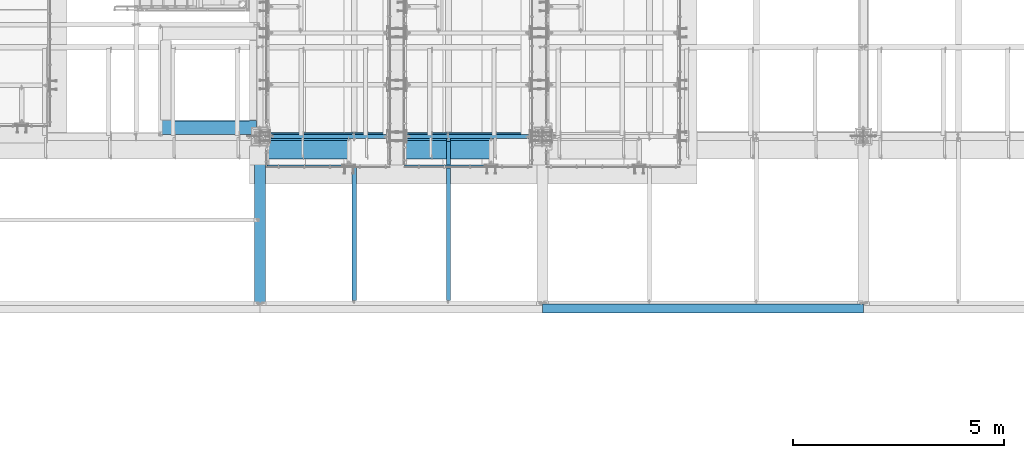
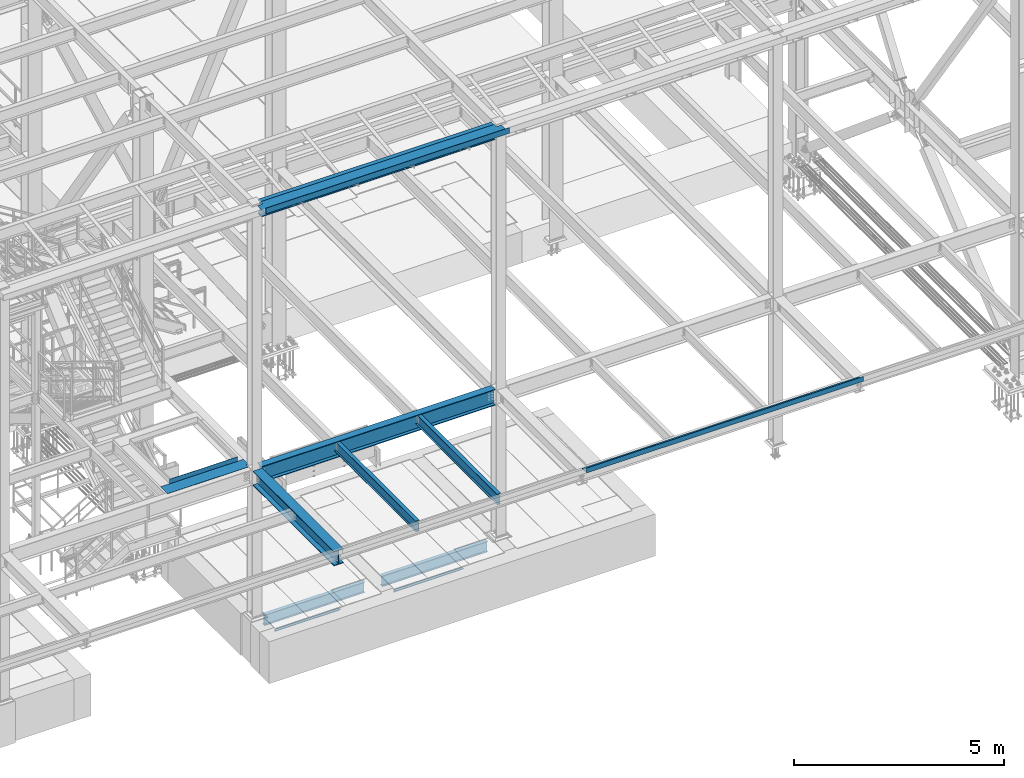
# One storey, part 1751 of 3843: 12 beams, 11 elements without a shape of their own.
"""IFC2X3 building model written with IfcOpenShell, lengths in millimetres."""

from ifc_helpers import new_model, si_unit, frame, origin_with_axes, place, context, subcontext, project, spatial, faceted_brep, material, type_object, element, aggregate, save


model = new_model("IFC2X3")

# Units and contexts
model_context = context("Model", 3, precision=1e-05, world=origin_with_axes())
body_context = subcontext(model_context, "Body", "Model", "MODEL_VIEW")
ifc_project = project(units=[si_unit("LENGTHUNIT", "METRE", prefix="MILLI"), si_unit("AREAUNIT", "SQUARE_METRE"), si_unit("VOLUMEUNIT", "CUBIC_METRE"), si_unit("MASSUNIT", "GRAM", prefix="KILO"), si_unit("TIMEUNIT", "SECOND"), si_unit("PLANEANGLEUNIT", "RADIAN"), si_unit("SOLIDANGLEUNIT", "STERADIAN"), si_unit("THERMODYNAMICTEMPERATUREUNIT", "DEGREE_CELSIUS"), si_unit("LUMINOUSINTENSITYUNIT", "LUMEN")], contexts=[model_context])

# Site, building, storey
site_placement = place(None, origin_with_axes())
site = spatial("IfcSite", under=ifc_project, at=site_placement, CompositionType="ELEMENT")
building_placement = place(site_placement, origin_with_axes())
building = spatial("IfcBuilding", under=site, at=building_placement, Name="Undefined", CompositionType="ELEMENT")
storey_placement = place(building_placement, origin_with_axes())
storey = spatial("IfcBuildingStorey", under=building, at=storey_placement, Name="Undefined", CompositionType="ELEMENT", Elevation=0.0)

# Assembly, beam
assembly_1_placement = place(storey_placement, origin_with_axes())
assembly_1 = element("IfcElementAssembly", 1, at=assembly_1_placement, inside=storey, Name="ANGLE", AssemblyPlace="NOTDEFINED", PredefinedType="RIGID_FRAME")
ifc_material_1 = material(Name="STEEL/A36")
beam_type_1 = type_object("IfcBeamType", Name="L3X3X1/4", PredefinedType="NOTDEFINED")
beam_1_placement = place(assembly_1_placement, frame((57873.8999936549, 14290.6743626722, 30391.1000030518), z_axis=(0.0, 0.0, -1.0), x_axis=(-1.0, 0.0, 0.0)))
beam_1 = element("IfcBeam", 2, at=beam_1_placement, type_object=beam_type_1, material=ifc_material_1, Name="ANGLE", ObjectType="L3X3X1/4", context=body_context, shape_type="Brep", body=[
    faceted_brep([(0.0, 38.0999999999985, -38.0999999999985), (0.0, 38.0999999999985, 38.0999999999985), (1784.34998101931, 38.0999999996202, 38.0999999999985), (1784.34998101931, 38.0999999996202, -38.0999999999985), (0.0, 31.75, 38.0999999999985), (1784.34998101932, 31.7499999996198, 38.0999999999985), (0.0, 31.75, -31.75), (1784.34998101932, 31.7499999996198, -31.75), (0.0, -38.0999999999985, -31.75), (1784.34998101943, -38.1000000003805, -31.75), (0.0, -38.0999999999985, -38.0999999999985), (1784.34998101943, -38.1000000003805, -38.0999999999985)], [[[0, 1, 2, 3]], [[1, 4, 5, 2]], [[4, 6, 7, 5]], [[6, 8, 9, 7]], [[8, 10, 11, 9]], [[10, 0, 3, 11]], [[5, 7, 9, 11, 3, 2]], [[10, 8, 6, 4, 1, 0]]]),
])
aggregate(assembly_1, [beam_1])

assembly_2_placement = place(storey_placement, origin_with_axes())
assembly_2 = element("IfcElementAssembly", 3, at=assembly_2_placement, inside=storey, Name="ANGLE", AssemblyPlace="NOTDEFINED", PredefinedType="RIGID_FRAME")
beam_2_placement = place(assembly_2_placement, frame((61255.2750461689, 14290.6746402423, 30391.1000030518), z_axis=(0.0, 0.0, -1.0), x_axis=(-1.0, 0.0, 0.0)))
beam_2 = element("IfcBeam", 4, at=beam_2_placement, type_object=beam_type_1, material=ifc_material_1, Name="ANGLE", ObjectType="L3X3X1/4", context=body_context, shape_type="Brep", body=[
    faceted_brep([(0.0, 38.0999999999985, -38.0999999999985), (0.0, 38.0999999999985, 38.0999999999985), (1895.47503339566, 38.0999999996784, 38.0999999999985), (1895.47503339566, 38.0999999996784, -38.0999999999985), (0.0, 31.75, 38.0999999999985), (1895.47503339566, 31.749999999678, 38.0999999999985), (0.0, 31.75, -31.75), (1895.47503339566, 31.749999999678, -31.75), (0.0, -38.0999999999985, -31.75), (1895.47503339565, -38.1000000003205, -31.75), (0.0, -38.0999999999985, -38.0999999999985), (1895.47503339565, -38.1000000003205, -38.0999999999985)], [[[0, 1, 2, 3]], [[1, 4, 5, 2]], [[4, 6, 7, 5]], [[6, 8, 9, 7]], [[8, 10, 11, 9]], [[10, 0, 3, 11]], [[5, 7, 9, 11, 3, 2]], [[10, 8, 6, 4, 1, 0]]]),
])
aggregate(assembly_2, [beam_2])

assembly_3_placement = place(storey_placement, origin_with_axes())
assembly_3 = element("IfcElementAssembly", 5, at=assembly_3_placement, inside=storey, Name="BEAM", AssemblyPlace="NOTDEFINED", PredefinedType="RIGID_FRAME")
ifc_material_2 = material(Name="STEEL/A992")
beam_type_2 = type_object("IfcBeamType", Name="W12X19", PredefinedType="NOTDEFINED")
beam_3_placement = place(assembly_3_placement, frame((58166.0, 11036.3, 34656.7125), z_axis=(0.0, 0.0, 1.0), x_axis=(0.0, 1.0, 0.0)))
beam_3 = element("IfcBeam", 6, at=beam_3_placement, type_object=beam_type_2, material=ifc_material_2, Name="BEAM", ObjectType="W12X19", context=body_context, shape_type="Brep", body=[
    faceted_brep([(15.8750000000146, -3.17500000000291, -128.587499998961), (15.8750000000146, 3.17500000000291, -128.587499998961), (53.9750001907523, 3.17500000000291, -128.587499998961), (53.9750001907523, -3.17500000000291, -128.587499998961), (58.8350797087915, 3.17500000000291, -129.554229921552), (58.8350797087915, -3.17500000000291, -129.554229921552), (62.9552561769524, 3.17500000000291, -132.307243822026), (62.9552561769524, -3.17500000000291, -132.307243822026), (65.7082700774336, 3.17500000000291, -136.42742029018), (65.7082700774336, -3.17500000000291, -136.42742029018), (66.6750000000175, -3.17500000000291, -141.287499808226), (66.6750000000175, 3.17500000000291, -141.287499808226), (66.6750000000175, 3.17500000000291, -144.462500000001), (66.6750000000175, 50.8000000000029, -144.462500000001), (66.6750000000175, 50.8000000000029, -153.987500000003), (66.6750000000175, -50.8000000000029, -153.987500000003), (66.6750000000175, -50.8000000000029, -144.462500000001), (66.6750000000175, -3.17500000000291, -144.462500000001), (3848.89375, 50.8000000000029, 144.462500000001), (3848.89375, 3.17500000000291, 144.462500000001), (66.6750000000175, 3.17500000000291, 144.462500000001), (66.6750000000175, 50.8000000000029, 144.462500000001), (53.9750001907523, -3.17500000000291, 128.587500001042), (53.9750001907523, 3.17500000000291, 128.587500001042), (15.8750000000146, 3.17500000000291, 128.587500001042), (15.8750000000146, -3.17500000000291, 128.587500001042), (58.8350797087915, -3.17500000000291, 129.554229923633), (58.8350797087915, 3.17500000000291, 129.554229923633), (62.9552561769524, -3.17500000000291, 132.307243824107), (62.9552561769524, 3.17500000000291, 132.307243824107), (65.7082700774336, -3.17500000000291, 136.427420292261), (65.7082700774336, 3.17500000000291, 136.427420292261), (66.6750000000175, -3.17500000000291, 141.287499810307), (66.6750000000175, 3.17500000000291, 141.287499810307), (3848.89375, -50.8000000000029, 153.987500000003), (3848.89375, 50.8000000000029, 153.987500000003), (66.6750000000175, 50.8000000000029, 153.987500000003), (66.6750000000175, -50.8000000000029, 153.987500000003), (3848.89375, -50.8000000000029, 144.462500000001), (66.6750000000175, -50.8000000000029, 144.462500000001), (3848.89375, -3.17500000000291, 144.462500000001), (66.6750000000175, -3.17500000000291, 144.462500000001), (3848.89375, -3.17500000000291, 134.937499809275), (3848.89375, 3.17500000000291, 134.937499809275), (3849.86047992259, -3.17500000000291, 130.077420291229), (3849.86047992259, 3.17500000000291, 130.077420291229), (3852.61349382307, -3.17500000000291, 125.957243823075), (3852.61349382307, 3.17500000000291, 125.957243823075), (3856.73367029122, -3.17500000000291, 123.204229922601), (3856.73367029122, 3.17500000000291, 123.204229922601), (3861.59374980927, -3.17500000000291, 122.23750000001), (3861.59374980927, 3.17500000000291, 122.23750000001), (3944.14375, -3.17500000000291, 122.23750000001), (3944.14375, 3.17500000000291, 122.23750000001), (3944.14375, -3.17500000000291, -144.462500000001), (3944.14375, -50.8000000000029, -144.462500000001), (3944.14375, -50.8000000000029, -153.987500000003), (3944.14375, 50.8000000000029, -153.987500000003), (3944.14375, 50.8000000000029, -144.462500000001), (3944.14375, 3.17500000000291, -144.462500000001), (3944.14375, 3.17500000000291, -114.712500000001), (3944.14375, 3.17500000000291, 115.887499999997), (15.8750000000146, 3.17500000000291, -114.712499998386), (15.8750000000146, 3.17500000000291, 115.887500001612)], [[[0, 1, 2, 3]], [[3, 2, 4, 5]], [[5, 4, 6, 7]], [[7, 6, 8, 9]], [[10, 11, 12, 13, 14, 15, 16, 17]], [[9, 8, 11, 10]], [[18, 19, 20, 21]], [[22, 23, 24, 25]], [[26, 27, 23, 22]], [[28, 29, 27, 26]], [[30, 31, 29, 28]], [[32, 33, 31, 30]], [[34, 35, 36, 37]], [[38, 34, 37, 39]], [[40, 38, 39, 41]], [[37, 36, 21, 20, 33, 32, 41, 39]], [[35, 18, 21, 36]], [[34, 38, 40, 42, 43, 19, 18, 35]], [[44, 45, 43, 42]], [[46, 47, 45, 44]], [[48, 49, 47, 46]], [[50, 51, 49, 48]], [[52, 53, 51, 50]], [[54, 55, 56, 57, 58, 59, 60, 61, 53, 52]], [[55, 54, 17, 16]], [[56, 55, 16, 15]], [[57, 56, 15, 14]], [[58, 57, 14, 13]], [[59, 58, 13, 12]], [[6, 4, 2, 1, 62, 63, 24, 23, 27, 29, 31, 33, 20, 19, 43, 45, 47, 49, 51, 53, 61, 60, 59, 12, 11, 8]], [[25, 24, 63, 62, 1, 0]], [[54, 52, 50, 48, 46, 44, 42, 40, 41, 32, 30, 28, 26, 22, 25, 0, 3, 5, 7, 9, 10, 17]]]),
])
aggregate(assembly_3, [beam_3])

assembly_4_placement = place(storey_placement, origin_with_axes())
assembly_4 = element("IfcElementAssembly", 7, at=assembly_4_placement, inside=storey, Name="BEAM", AssemblyPlace="NOTDEFINED", PredefinedType="RIGID_FRAME")
beam_4_placement = place(assembly_4_placement, frame((60401.2, 11036.3, 34656.7125), z_axis=(0.0, 0.0, 1.0), x_axis=(0.0, 1.0, 0.0)))
beam_4 = element("IfcBeam", 8, at=beam_4_placement, type_object=beam_type_2, material=ifc_material_2, Name="BEAM", ObjectType="W12X19", context=body_context, shape_type="Brep", body=[
    faceted_brep([(3848.89375, -50.8000000000029, 153.987500000003), (3848.89375, -50.8000000000029, 144.462500000001), (3848.89375, -3.17500000000291, 144.462500000001), (3848.89375, -3.17500000000291, 134.937499809275), (3848.89375, 3.17500000000291, 134.937499809275), (3848.89375, 3.17500000000291, 144.462500000001), (3848.89375, 50.8000000000029, 144.462500000001), (3848.89375, 50.8000000000029, 153.987500000003), (3849.86047992259, -3.17500000000291, 130.077420291229), (3849.86047992259, 3.17500000000291, 130.077420291229), (3852.61349382307, -3.17500000000291, 125.957243823075), (3852.61349382307, 3.17500000000291, 125.957243823075), (3856.73367029122, -3.17500000000291, 123.204229922601), (3856.73367029122, 3.17500000000291, 123.204229922601), (3861.59374980927, -3.17500000000291, 122.23750000001), (3861.59374980927, 3.17500000000291, 122.23750000001), (3944.14375, -3.17500000000291, 122.23750000001), (3944.14375, 3.17500000000291, 122.23750000001), (66.6750000000175, -50.8000000000029, 153.987500000003), (66.6750000000175, 50.8000000000029, 153.987500000003), (66.6750000000175, 50.8000000000029, 144.462500000001), (66.6750000000175, 3.17500000000291, 144.462500000001), (66.6750000000175, 3.17500000000291, 141.287499810307), (66.6750000000175, -3.17500000000291, 141.287499810307), (66.6750000000175, -3.17500000000291, 144.462500000001), (66.6750000000175, -50.8000000000029, 144.462500000001), (65.7082700774336, 3.17500000000291, 136.427420292261), (65.7082700774336, -3.17500000000291, 136.427420292261), (62.9552561769524, 3.17500000000291, 132.307243824107), (62.9552561769524, -3.17500000000291, 132.307243824107), (58.8350797087915, 3.17500000000291, 129.554229923633), (58.8350797087915, -3.17500000000291, 129.554229923633), (53.9750001907523, 3.17500000000291, 128.587500001042), (53.9750001907523, -3.17500000000291, 128.587500001042), (15.8750000000146, 3.17500000000291, 128.587500001042), (15.8750000000146, -3.17500000000291, 128.587500001042), (15.8750000000146, 3.17500000000291, 115.887500001612), (15.8750000000146, 3.17500000000291, -114.712499998386), (15.8750000000146, 3.17500000000291, -128.587499998961), (15.8750000000146, -3.17500000000291, -128.587499998961), (53.9750001907523, 3.17500000000291, -128.587499998961), (53.9750001907523, -3.17500000000291, -128.587499998961), (58.8350797087915, 3.17500000000291, -129.554229921552), (58.8350797087915, -3.17500000000291, -129.554229921552), (62.9552561769524, 3.17500000000291, -132.307243822026), (62.9552561769524, -3.17500000000291, -132.307243822026), (65.7082700774336, 3.17500000000291, -136.42742029018), (65.7082700774336, -3.17500000000291, -136.42742029018), (66.6750000000175, 3.17500000000291, -141.287499808226), (66.6750000000175, -3.17500000000291, -141.287499808226), (3944.14375, 3.17500000000291, -144.462500000001), (3944.14375, 50.8000000000029, -144.462500000001), (66.6750000000175, 50.8000000000029, -144.462500000001), (66.6750000000175, 3.17500000000291, -144.462500000001), (3944.14375, 50.8000000000029, -153.987500000003), (66.6750000000175, 50.8000000000029, -153.987500000003), (3944.14375, -50.8000000000029, -153.987500000003), (66.6750000000175, -50.8000000000029, -153.987500000003), (3944.14375, -50.8000000000029, -144.462500000001), (66.6750000000175, -50.8000000000029, -144.462500000001), (66.6750000000175, -3.17500000000291, -144.462500000001), (3944.14375, -3.17500000000291, -144.462500000001), (3944.14375, 3.17500000000291, 115.887499999997), (3944.14375, 3.17500000000291, -114.712500000001)], [[[0, 1, 2, 3, 4, 5, 6, 7]], [[8, 9, 4, 3]], [[10, 11, 9, 8]], [[12, 13, 11, 10]], [[14, 15, 13, 12]], [[16, 17, 15, 14]], [[18, 19, 20, 21, 22, 23, 24, 25]], [[23, 22, 26, 27]], [[27, 26, 28, 29]], [[29, 28, 30, 31]], [[31, 30, 32, 33]], [[33, 32, 34, 35]], [[35, 34, 36, 37, 38, 39]], [[39, 38, 40, 41]], [[41, 40, 42, 43]], [[43, 42, 44, 45]], [[45, 44, 46, 47]], [[47, 46, 48, 49]], [[50, 51, 52, 53]], [[51, 54, 55, 52]], [[54, 56, 57, 55]], [[56, 58, 59, 57]], [[49, 48, 53, 52, 55, 57, 59, 60]], [[58, 61, 60, 59]], [[61, 16, 14, 12, 10, 8, 3, 2, 24, 23, 27, 29, 31, 33, 35, 39, 41, 43, 45, 47, 49, 60]], [[2, 1, 25, 24]], [[1, 0, 18, 25]], [[0, 7, 19, 18]], [[7, 6, 20, 19]], [[6, 5, 21, 20]], [[44, 42, 40, 38, 37, 36, 34, 32, 30, 28, 26, 22, 21, 5, 4, 9, 11, 13, 15, 17, 62, 63, 50, 53, 48, 46]], [[61, 58, 56, 54, 51, 50, 63, 62, 17, 16]]]),
])
aggregate(assembly_4, [beam_4])

assembly_5_placement = place(storey_placement, origin_with_axes())
assembly_5 = element("IfcElementAssembly", 9, at=assembly_5_placement, inside=storey, Name="BEAM", AssemblyPlace="NOTDEFINED", PredefinedType="RIGID_FRAME")
beam_type_3 = type_object("IfcBeamType", Name="W18X65", PredefinedType="NOTDEFINED")
beam_5_placement = place(assembly_5_placement, frame((55930.8, 14998.7, 34577.3375), z_axis=(0.0, 0.0, 1.0), x_axis=(1.0, 0.0, 0.0)))
beam_5 = element("IfcBeam", 10, at=beam_5_placement, type_object=beam_type_3, material=ifc_material_2, Name="BEAM", ObjectType="W18X65", context=body_context, shape_type="Brep", body=[
    faceted_brep([(141.287499999991, 96.8374999999996, -233.362500000003), (141.287499999991, 96.8374999999996, -214.3125), (6564.3125, 96.8374999999996, -214.3125), (6564.3125, 96.8374999999996, -233.362500000003), (141.287499999991, 5.55624999999964, -214.3125), (6564.3125, 5.55624999999964, -214.3125), (141.287499999991, 5.55624999999964, 214.3125), (6564.3125, 5.55624999999964, 214.3125), (141.287499999991, 96.8374999999996, 214.3125), (6564.3125, 96.8374999999996, 214.3125), (141.287499999991, 96.8374999999996, 233.362500000003), (6564.3125, 96.8374999999996, 233.362500000003), (141.287499999991, -96.8374999999996, 233.362500000003), (6564.3125, -96.8374999999996, 233.362500000003), (141.287499999991, -96.8374999999996, 214.3125), (6564.3125, -96.8374999999996, 214.3125), (141.287499999991, -5.55624999999964, 214.3125), (6564.3125, -5.55624999999964, 214.3125), (141.287499999991, -5.55624999999964, -214.3125), (6564.3125, -5.55624999999964, -214.3125), (141.287499999991, -96.8374999999996, -214.3125), (6564.3125, -96.8374999999996, -214.3125), (141.287499999991, -96.8374999999996, -233.362500000003), (6564.3125, -96.8374999999996, -233.362500000003)], [[[0, 1, 2, 3]], [[1, 4, 5, 2]], [[4, 6, 7, 5]], [[6, 8, 9, 7]], [[8, 10, 11, 9]], [[10, 12, 13, 11]], [[12, 14, 15, 13]], [[14, 16, 17, 15]], [[16, 18, 19, 17]], [[18, 20, 21, 19]], [[20, 22, 23, 21]], [[22, 0, 3, 23]], [[5, 7, 9, 11, 13, 15, 17, 19, 21, 23, 3, 2]], [[22, 20, 18, 16, 14, 12, 10, 8, 6, 4, 1, 0]]]),
])
aggregate(assembly_5, [beam_5])

assembly_6_placement = place(storey_placement, origin_with_axes())
assembly_6 = element("IfcElementAssembly", 11, at=assembly_6_placement, inside=storey, Name="BEAM", AssemblyPlace="NOTDEFINED", PredefinedType="RIGID_FRAME")
beam_type_4 = type_object("IfcBeamType", PredefinedType="NOTDEFINED")
beam_6_placement = place(assembly_6_placement, frame((59283.6, 14960.6, 42471.975), z_axis=(-1.0, 0.0, 0.0), x_axis=(0.0, -1.0, 0.0)))
beam_6 = element("IfcBeam", 12, at=beam_6_placement, type_object=beam_type_4, material=ifc_material_1, Name="BENT_PLATE", context=body_context, shape_type="Brep", body=[
    faceted_brep([(104.775, -3.17500000000291, 3211.5125), (104.775, 3.17500000000291, 3211.5125), (0.0, 3.17500000000291, 3211.5125), (0.0, -3.17500000000291, 3211.5125), (104.775, -3.17500000000291, 3349.6255), (104.775, 3.17500000000291, 3349.6255), (0.0, -3.17500000000291, -3211.5125), (0.0, 3.17500000000291, -3211.5125), (104.774999999985, 3.17500000000291, -3211.51250000002), (104.774999999985, -3.17500000000291, -3211.51250000002), (104.775, 3.17500000000291, -3349.6255), (104.775, -3.17500000000291, -3349.6255), (488.949999999997, 3.17500000000291, -3349.6255), (488.949999999997, 161.924999999996, -3349.6255), (495.299999999996, 161.924999999996, -3349.6255), (495.299999999996, -3.17500000000291, -3349.6255), (488.949999999997, 3.17500000000291, 3349.6255), (488.949999999997, 161.924999999996, 3349.6255), (495.299999999996, 161.924999999996, 3349.6255), (495.299999999996, -3.17500000000291, 3349.6255)], [[[0, 1, 2, 3]], [[4, 5, 1, 0]], [[6, 7, 8, 9]], [[9, 8, 10, 11]], [[12, 13, 14, 15, 11, 10]], [[12, 16, 17, 13]], [[18, 14, 13, 17]], [[19, 15, 14, 18]], [[3, 6, 9, 11, 15, 19, 4, 0]], [[7, 6, 3, 2]], [[16, 12, 10, 8, 7, 2, 1, 5]], [[19, 18, 17, 16, 5, 4]]]),
])

assembly_7_placement = place(storey_placement, origin_with_axes())
assembly_7 = element("IfcElementAssembly", 13, at=assembly_7_placement, inside=storey, AssemblyPlace="NOTDEFINED", PredefinedType="RIGID_FRAME")
ifc_material_3 = material(Name="STEEL/A572-50")
beam_type_5 = type_object("IfcBeamType", PredefinedType="NOTDEFINED")
beam_7_placement = place(assembly_7_placement, frame((54710.012, 15043.15, 34813.875), z_axis=(-1.0, 0.0, 0.0), x_axis=(0.0, 1.0, 0.0)))
beam_7 = element("IfcBeam", 14, at=beam_7_placement, type_object=beam_type_5, material=ifc_material_3, context=body_context, shape_type="Brep", body=[
    faceted_brep([(98.4249999999993, -3.17500000000291, -1079.5005), (98.4249999999993, 3.17500000000291, -1079.5005), (98.4250000000011, 3.17500000000291, -1141.4125), (98.4250000000011, -3.17500000000291, -1141.4125), (0.0, -3.17500000000291, -1079.50049999999), (0.0, 3.17500000000291, -1079.50049999999), (330.199987792967, -136.524996948247, -973.137999999999), (336.549987792965, -136.524996948247, -973.137999999999), (336.549987792965, -136.524996948247, 893.762000000017), (330.199987792967, -136.524996948247, 893.762000000017), (336.549987792971, -3.17500610351999, -973.137999999999), (336.549987792971, -3.17500610351999, -1141.4125), (336.549987792972, 3.17500000000291, -1141.4125), (336.549987792972, 3.17500000000291, 1141.4125), (336.549987792971, -3.17500610351271, 1141.41249743654), (336.549987792971, -3.17500610351271, 893.762000000017), (0.0, 3.17500000000291, 1141.4125), (0.0, -3.17500000000291, 1141.4125), (330.199987792972, -3.17500000000291, 1141.4125), (330.199987792972, -3.17500000000291, 893.762000000017), (330.199987792972, -3.17500000000291, -973.137999999999), (330.199987792972, -3.17500000000291, -1141.4125), (0.0, -3.17500000000291, -973.137999999999), (0.0, -3.17500000000291, 893.762000000017)], [[[0, 1, 2, 3]], [[4, 5, 1, 0]], [[6, 7, 8, 9]], [[8, 7, 10, 11, 12, 13, 14, 15]], [[13, 16, 17, 18, 14]], [[14, 18, 19, 15]], [[8, 15, 19, 9]], [[20, 6, 9, 19]], [[7, 6, 20, 10]], [[10, 20, 21, 11]], [[12, 11, 21, 3, 2]], [[16, 13, 12, 2, 1, 5]], [[22, 23, 17, 16, 5, 4]], [[21, 20, 19, 18, 17, 23, 22, 4, 0, 3]]]),
])
aggregate(assembly_7, [beam_7])

assembly_8_placement = place(storey_placement, origin_with_axes())
assembly_8 = element("IfcElementAssembly", 15, at=assembly_8_placement, inside=storey, Name="BEAM", AssemblyPlace="NOTDEFINED", PredefinedType="RIGID_FRAME")
beam_type_6 = type_object("IfcBeamType", PredefinedType="NOTDEFINED")
beam_8_placement = place(assembly_8_placement, frame((66446.40025, 11023.6, 34813.875), z_axis=(-1.0, 0.0, 0.0), x_axis=(0.0, -1.0, 0.0)))
beam_8 = element("IfcBeam", 16, at=beam_8_placement, type_object=beam_type_6, material=ifc_material_1, Name="BENT_PLATE", context=body_context, shape_type="Brep", body=[
    faceted_brep([(0.0, -3.17500000000291, -3806.82500000006), (0.0, -3.17500000000291, 3806.825), (0.0, 3.17500000000291, 3806.825), (0.0, 3.17500000000291, -3806.825), (209.549993896482, 3.17500000000291, 3806.825), (209.549993896482, 3.17500000000291, -3806.825), (215.899993896481, -3.17500000000291, -3806.825), (215.899993896481, -3.17500000000291, 3806.825), (209.549993896482, 136.524996948239, 3806.825), (209.549993896482, 136.524996948239, -3806.825), (215.899993896481, 136.524996948239, 3806.825), (215.899993896481, 136.524996948239, -3806.825)], [[[0, 1, 2, 3]], [[3, 2, 4, 5]], [[1, 0, 6, 7]], [[5, 4, 8, 9]], [[4, 2, 1, 7, 10, 8]], [[7, 6, 11, 10]], [[6, 0, 3, 5, 9, 11]], [[10, 11, 9, 8]]]),
])
aggregate(assembly_8, [beam_8])

# Beam
beam_type_7 = type_object("IfcBeamType", Name="W16X40", PredefinedType="NOTDEFINED")
beam_9_placement = place(assembly_6_placement, frame((55930.8, 14998.7, 42265.6), z_axis=(0.0, 0.0, 1.0), x_axis=(1.0, 0.0, 0.0)))
beam_9 = element("IfcBeam", 17, at=beam_9_placement, type_object=beam_type_7, material=ifc_material_2, Name="BEAM", ObjectType="W16X40", context=body_context, shape_type="Brep", body=[
    faceted_brep([(141.287499999999, -88.8999999999996, -203.199999999997), (141.287499999999, 88.8999999999996, -203.199999999997), (6564.31249999999, 88.8999999999996, -203.199999999997), (6564.31249999999, -88.8999999999996, -203.199999999997), (141.287499999999, -88.8999999999996, -190.5), (141.287499999999, -3.96875, -190.5), (141.287499999999, -3.96875, 190.5), (141.287499999999, -88.8999999999996, 190.5), (141.287499999999, -88.8999999999996, 203.199999999997), (141.287499999999, 88.8999999999996, 203.199999999997), (141.287499999999, 88.8999999999996, 190.5), (141.287499999999, 3.96875, 190.5), (141.287499999999, 3.96875, 165.839999999997), (141.287499999999, 3.96875, -153.139999999999), (141.287499999999, 3.96875, -190.5), (141.287499999999, 88.8999999999996, -190.5), (6564.31249999999, -88.8999999999996, -190.5), (6564.31249999999, -3.96875, -190.5), (6564.31249999999, -3.96875, 190.5), (6564.31249999999, -88.8999999999996, 190.5), (6564.31249999999, -88.8999999999996, 203.199999999997), (6564.31249999999, 88.8999999999996, 203.199999999997), (6564.31249999999, 88.8999999999996, 190.5), (6564.31249999999, 3.96875, 190.5), (6564.31249999999, 3.96875, 165.839999999997), (6564.31249999999, 3.96875, -153.139999999999), (6564.31249999999, 3.96875, -190.5), (6564.31249999999, 88.8999999999996, -190.5)], [[[0, 1, 2, 3]], [[0, 4, 5, 6, 7, 8, 9, 10, 11, 12, 13, 14, 15, 1]], [[5, 4, 16, 17]], [[6, 5, 17, 18]], [[7, 6, 18, 19]], [[8, 7, 19, 20]], [[9, 8, 20, 21]], [[10, 9, 21, 22]], [[11, 10, 22, 23]], [[14, 13, 12, 11, 23, 24, 25, 26]], [[15, 14, 26, 27]], [[1, 15, 27, 2]], [[26, 25, 24, 23, 22, 21, 20, 19, 18, 17, 16, 3, 2, 27]], [[4, 0, 3, 16]]]),
])

aggregate(assembly_6, [beam_6, beam_9])

# Assembly, beam
assembly_9_placement = place(storey_placement, origin_with_axes())
assembly_9 = element("IfcElementAssembly", 18, at=assembly_9_placement, inside=storey, Name="BEAM", AssemblyPlace="NOTDEFINED", PredefinedType="RIGID_FRAME")
beam_type_8 = type_object("IfcBeamType", Name="W12X22", PredefinedType="NOTDEFINED")
beam_10_placement = place(assembly_9_placement, frame((59410.6, 14998.7, 30273.625), z_axis=(0.0, 0.0, 1.0), x_axis=(1.0, 0.0, 0.0)))
beam_10 = element("IfcBeam", 19, at=beam_10_placement, type_object=beam_type_8, material=ifc_material_2, Name="BEAM", ObjectType="W12X22", context=body_context, shape_type="Brep", body=[
    faceted_brep([(12.7000030517593, 50.7999999999993, -155.575000000001), (12.7000030517593, 50.7999999999993, -144.462500000001), (2908.29999694825, 50.7999999999993, -144.462500000001), (2908.29999694825, 50.7999999999993, -155.575000000001), (12.7000030517593, 3.17499999999927, -144.462500000001), (2908.29999694825, 3.17499999999927, -144.462500000001), (12.7000030517593, 3.17499999999927, 144.462500000001), (2908.29999694825, 3.17499999999927, 144.462500000001), (12.7000030517593, 50.7999999999993, 144.462500000001), (2908.29999694825, 50.7999999999993, 144.462500000001), (12.7000030517593, 50.7999999999993, 155.575000000001), (2908.29999694825, 50.7999999999993, 155.575000000001), (12.7000030517593, -50.7999999999993, 155.575000000001), (2908.29999694825, -50.7999999999993, 155.575000000001), (12.7000030517593, -50.7999999999993, 144.462500000001), (2908.29999694825, -50.7999999999993, 144.462500000001), (12.7000030517593, -3.17499999999927, 144.462500000001), (2908.29999694825, -3.17499999999927, 144.462500000001), (12.7000030517593, -3.17499999999927, -144.462500000001), (2908.29999694825, -3.17499999999927, -144.462500000001), (12.7000030517593, -50.7999999999993, -144.462500000001), (2908.29999694825, -50.7999999999993, -144.462500000001), (12.7000030517593, -50.7999999999993, -155.575000000001), (2908.29999694825, -50.7999999999993, -155.575000000001)], [[[0, 1, 2, 3]], [[1, 4, 5, 2]], [[4, 6, 7, 5]], [[6, 8, 9, 7]], [[8, 10, 11, 9]], [[10, 12, 13, 11]], [[12, 14, 15, 13]], [[14, 16, 17, 15]], [[16, 18, 19, 17]], [[18, 20, 21, 19]], [[20, 22, 23, 21]], [[22, 0, 3, 23]], [[5, 7, 9, 11, 13, 15, 17, 19, 21, 23, 3, 2]], [[22, 20, 18, 16, 14, 12, 10, 8, 6, 4, 1, 0]]]),
])
aggregate(assembly_9, [beam_10])

assembly_10_placement = place(storey_placement, origin_with_axes())
assembly_10 = element("IfcElementAssembly", 20, at=assembly_10_placement, inside=storey, Name="BEAM", AssemblyPlace="NOTDEFINED", PredefinedType="RIGID_FRAME")
beam_11_placement = place(assembly_10_placement, frame((56235.6, 14998.7, 30273.625), z_axis=(0.0, 0.0, 1.0), x_axis=(1.0, 0.0, 0.0)))
beam_11 = element("IfcBeam", 21, at=beam_11_placement, type_object=beam_type_8, material=ifc_material_2, Name="BEAM", ObjectType="W12X22", context=body_context, shape_type="Brep", body=[
    faceted_brep([(-50.8000000000029, 50.7999999999993, -155.575000000001), (-50.8000000000029, 50.7999999999993, -144.462500000001), (2705.09999694825, 50.7999999999993, -144.462500000001), (2705.09999694825, 50.7999999999993, -155.575000000001), (-50.8000000000029, 3.17499999999927, -144.462500000001), (2705.09999694825, 3.17499999999927, -144.462500000001), (-50.8000000000029, 3.17499999999927, 144.462500000001), (2705.09999694825, 3.17499999999927, 144.462500000001), (-50.8000000000029, 50.7999999999993, 144.462500000001), (2705.09999694825, 50.7999999999993, 144.462500000001), (-50.8000000000029, 50.7999999999993, 155.575000000001), (2705.09999694825, 50.7999999999993, 155.575000000001), (-50.8000000000029, -50.7999999999993, 155.575000000001), (2705.09999694825, -50.7999999999993, 155.575000000001), (-50.8000000000029, -50.7999999999993, 144.462500000001), (2705.09999694825, -50.7999999999993, 144.462500000001), (-50.8000000000029, -3.17499999999927, 144.462500000001), (2705.09999694825, -3.17499999999927, 144.462500000001), (-50.8000000000029, -3.17499999999927, -144.462500000001), (2705.09999694825, -3.17499999999927, -144.462500000001), (-50.8000000000029, -50.7999999999993, -144.462500000001), (2705.09999694825, -50.7999999999993, -144.462500000001), (-50.8000000000029, -50.7999999999993, -155.575000000001), (2705.09999694825, -50.7999999999993, -155.575000000001)], [[[0, 1, 2, 3]], [[1, 4, 5, 2]], [[4, 6, 7, 5]], [[6, 8, 9, 7]], [[8, 10, 11, 9]], [[10, 12, 13, 11]], [[12, 14, 15, 13]], [[14, 16, 17, 15]], [[16, 18, 19, 17]], [[18, 20, 21, 19]], [[20, 22, 23, 21]], [[22, 0, 3, 23]], [[5, 7, 9, 11, 13, 15, 17, 19, 21, 23, 3, 2]], [[22, 20, 18, 16, 14, 12, 10, 8, 6, 4, 1, 0]]]),
])
aggregate(assembly_10, [beam_11])

assembly_11_placement = place(storey_placement, origin_with_axes())
assembly_11 = element("IfcElementAssembly", 22, at=assembly_11_placement, inside=storey, Name="BEAM", AssemblyPlace="NOTDEFINED", PredefinedType="RIGID_FRAME")
beam_type_9 = type_object("IfcBeamType", Name="W16X77", PredefinedType="NOTDEFINED")
beam_12_placement = place(assembly_11_placement, frame((55930.8, 10985.5, 34601.15), z_axis=(0.0, 0.0, 1.0), x_axis=(0.0, 1.0, 0.0)))
beam_12 = element("IfcBeam", 23, at=beam_12_placement, type_object=beam_type_9, material=ifc_material_2, Name="BEAM", ObjectType="W16X77", context=body_context, shape_type="Brep", body=[
    faceted_brep([(3873.5, -130.175000000003, 190.5), (3873.5, -5.55625000000146, 190.5), (3873.5, 5.55625000000146, 190.5), (3873.5, 130.175000000003, 190.5), (3862.5014184705, 130.175000000003, 209.550000000003), (3862.5014184705, -130.175000000003, 209.550000000003), (0.0, -130.175000000003, -209.550000000003), (0.0, -130.175000000003, -190.5), (0.0, -5.55624999999418, -190.5), (0.0, -5.55624999999418, 190.5), (0.0, -130.175000000003, 190.5), (0.0, -130.175000000003, 209.550000000003), (0.0, 130.175000000003, 209.550000000003), (0.0, 130.175000000003, 190.5), (0.0, 5.55624999999418, 190.5), (0.0, 5.55624999999418, -190.5), (0.0, 130.175000000003, -190.5), (0.0, 130.175000000003, -209.550000000003), (3873.5, -5.55625000000146, 190.102999597169), (3873.5, 5.55625000000146, 190.102999597169), (3848.1, -5.55625000000146, 190.103000000003), (3848.1, 5.55625000000146, 190.103000000003), (3801.50655250839, -5.55625000000146, 180.790259445181), (3801.50655250839, 5.55625000000146, 180.790259445181), (3796.63324734029, -5.55625000000146, 178.180214995737), (3796.63324734029, 5.55625000000146, 178.180214995737), (3794.03040457438, -5.55625000000146, 173.303059592676), (3794.03040457438, 5.55625000000146, 173.303059592676), (3794.57480645528, -5.55625000000146, 167.80169050111), (3794.57480645528, 5.55625000000146, 167.80169050111), (3798.0830681434, -5.55625000000146, 163.529274882603), (3798.0830681434, 5.55625000000146, 163.529274882603), (3803.37341193097, -5.55625000000146, 161.925000000003), (3803.37341193097, 5.55625000000146, 161.925000000003), (3870.325, -5.55625000000146, 161.925000000003), (3870.325, 5.55625000000146, 161.925000000003), (3870.325, -5.55625000000146, -161.925000000003), (3870.325, 5.55625000000146, -161.925000000003), (3804.61641193097, -5.55625000000146, -161.925000000003), (3804.61641193097, 5.55625000000146, -161.925000000003), (3799.32606814341, -5.55625000000146, -163.529274882603), (3799.32606814341, 5.55625000000146, -163.529274882603), (3795.81780645529, -5.55625000000146, -167.80169050111), (3795.81780645529, 5.55625000000146, -167.80169050111), (3795.27340457438, -5.55625000000146, -173.303059592676), (3795.27340457438, 5.55625000000146, -173.303059592676), (3797.87624734029, -5.55625000000146, -178.180214995729), (3797.87624734029, 5.55625000000146, -178.180214995729), (3802.74955250839, -5.55625000000146, -180.790259445181), (3802.74955250839, 5.55625000000146, -180.790259445181), (3849.343, -5.55625000000146, -190.103000000003), (3849.343, 5.55625000000146, -190.103000000003), (3862.27220110753, -5.55625000000146, -190.102999786599), (3862.27220110753, 5.55625000000146, -190.102999786599), (3862.50140246148, 5.55625000000146, -190.5), (3862.50140246148, 130.175000000003, -190.5), (3873.5, 130.175000000003, -209.550000000003), (3873.5, -130.175000000003, -209.550000000003), (3862.50140246148, -130.175000000003, -190.5), (3862.50140246148, -5.55625000000146, -190.5)], [[[0, 1, 2, 3, 4, 5]], [[6, 7, 8, 9, 10, 11, 12, 13, 14, 15, 16, 17]], [[11, 10, 0, 5]], [[12, 11, 5, 4]], [[13, 12, 4, 3]], [[14, 13, 3, 2]], [[18, 19, 2, 1]], [[20, 21, 19, 18]], [[22, 23, 21, 20]], [[24, 25, 23, 22]], [[26, 27, 25, 24]], [[28, 29, 27, 26]], [[30, 31, 29, 28]], [[32, 33, 31, 30]], [[33, 32, 34, 35]], [[34, 36, 37, 35]], [[38, 39, 37, 36]], [[40, 41, 39, 38]], [[42, 43, 41, 40]], [[44, 45, 43, 42]], [[46, 47, 45, 44]], [[48, 49, 47, 46]], [[50, 51, 49, 48]], [[51, 50, 52, 53]], [[15, 14, 2, 19, 21, 23, 25, 27, 29, 31, 33, 35, 37, 39, 41, 43, 45, 47, 49, 51, 53, 54]], [[16, 15, 54, 55]], [[17, 16, 55, 56]], [[6, 17, 56, 57]], [[7, 6, 57, 58]], [[8, 7, 58, 59]], [[57, 56, 55, 54, 53, 52, 59, 58]], [[50, 48, 46, 44, 42, 40, 38, 36, 34, 32, 30, 28, 26, 24, 22, 20, 18, 1, 9, 8, 59, 52]], [[10, 9, 1, 0]]]),
])
aggregate(assembly_11, [beam_12])

save(model, "model.ifc")
